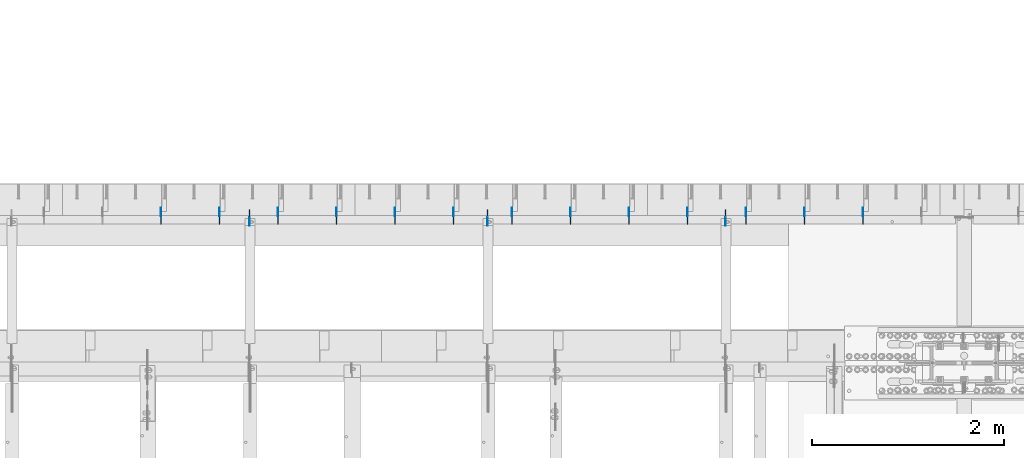
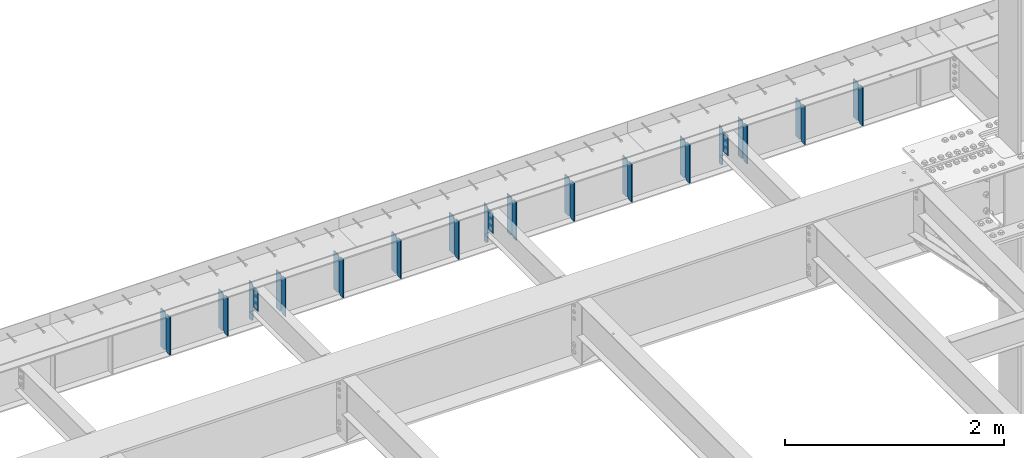
# One storey, part 1611 of 1763: 32 plates, 1 element without a shape of its own.
"""IFC2X3 building model written with IfcOpenShell, lengths in millimetres."""

from ifc_helpers import new_model, si_unit, frame, origin_with_axes, place, context, subcontext, project, spatial, faceted_brep, material, type_object, element, aggregate, save


model = new_model("IFC2X3")

# Units and contexts
model_context = context("Model", 3, precision=1e-05, world=origin_with_axes())
body_context = subcontext(model_context, "Body", "Model", "MODEL_VIEW")
ifc_project = project(units=[si_unit("LENGTHUNIT", "METRE", prefix="MILLI"), si_unit("AREAUNIT", "SQUARE_METRE"), si_unit("VOLUMEUNIT", "CUBIC_METRE"), si_unit("MASSUNIT", "GRAM", prefix="KILO"), si_unit("TIMEUNIT", "SECOND"), si_unit("PLANEANGLEUNIT", "RADIAN"), si_unit("SOLIDANGLEUNIT", "STERADIAN"), si_unit("THERMODYNAMICTEMPERATUREUNIT", "DEGREE_CELSIUS"), si_unit("LUMINOUSINTENSITYUNIT", "LUMEN")], contexts=[model_context])

# Site, building, storey
site_placement = place(None, origin_with_axes())
site = spatial("IfcSite", under=ifc_project, at=site_placement, CompositionType="ELEMENT")
building_placement = place(site_placement, origin_with_axes())
building = spatial("IfcBuilding", under=site, at=building_placement, Name="Undefined", CompositionType="ELEMENT")
storey_placement = place(building_placement, origin_with_axes())
storey = spatial("IfcBuildingStorey", under=building, at=storey_placement, Name="Undefined", CompositionType="ELEMENT", Elevation=0.0)

# Assembly, plates
assembly_placement = place(storey_placement, origin_with_axes())
assembly = element("IfcElementAssembly", 1, at=assembly_placement, inside=storey, Name="BEAM", AssemblyPlace="NOTDEFINED", PredefinedType="RIGID_FRAME")
ifc_material = material(Name="STEEL/A36")
plate_type_1 = type_object("IfcPlateType", PredefinedType="NOTDEFINED")
plate_1_placement = place(assembly_placement, frame((-73545.5341486984, 53568.6, 4752.975), z_axis=(0.0, 0.0, 1.0), x_axis=(0.0, 1.0, 0.0)))
plate_1 = element("IfcPlate", 2, at=plate_1_placement, type_object=plate_type_1, material=ifc_material, Name="PLATE", context=body_context, shape_type="Brep", body=[
    faceted_brep([(0.0, -4.76249999999982, 0.0), (0.0, -4.76249999999709, 428.625), (0.0, 4.76249999999709, 428.625), (0.0, 4.76249999999982, 0.0), (53.1812477111816, -4.76249999999709, 428.625), (53.1812477111816, 4.76249999999709, 428.625), (72.2312469482422, -4.76249999999709, 409.575000762939), (72.2312469482422, 4.76249999999709, 409.575000762939), (72.2312469482422, -4.76249999999709, 19.0499992370605), (72.2312469482422, 4.76249999999709, 19.0499992370605), (53.1812477111816, -4.76249999999709, 0.0), (53.1812477111816, 4.76249999999709, 0.0)], [[[0, 1, 2, 3]], [[1, 4, 5, 2]], [[4, 6, 7, 5]], [[6, 8, 9, 7]], [[8, 10, 11, 9]], [[10, 0, 3, 11]], [[5, 7, 9, 11, 3, 2]], [[10, 8, 6, 4, 1, 0]]]),
])
plate_2_placement = place(assembly_placement, frame((-74155.1341486984, 53568.6, 4752.975), z_axis=(0.0, 0.0, 1.0), x_axis=(0.0, 1.0, 0.0)))
plate_2 = element("IfcPlate", 3, at=plate_2_placement, type_object=plate_type_1, material=ifc_material, Name="PLATE", context=body_context, shape_type="Brep", body=[
    faceted_brep([(0.0, -4.76249999999982, 0.0), (0.0, -4.76249999999709, 428.625), (0.0, 4.76249999999709, 428.625), (0.0, 4.76249999999982, 0.0), (53.1812477111816, -4.76249999999709, 428.625), (53.1812477111816, 4.76249999999709, 428.625), (72.2312469482422, -4.76249999999709, 409.575000762939), (72.2312469482422, 4.76249999999709, 409.575000762939), (72.2312469482422, -4.76249999999709, 19.0499992370605), (72.2312469482422, 4.76249999999709, 19.0499992370605), (53.1812477111816, -4.76249999999709, 0.0), (53.1812477111816, 4.76249999999709, 0.0)], [[[0, 1, 2, 3]], [[1, 4, 5, 2]], [[4, 6, 7, 5]], [[6, 8, 9, 7]], [[8, 10, 11, 9]], [[10, 0, 3, 11]], [[5, 7, 9, 11, 3, 2]], [[10, 8, 6, 4, 1, 0]]]),
])
plate_3_placement = place(assembly_placement, frame((-74764.7341486983, 53568.6, 4752.975), z_axis=(0.0, 0.0, 1.0), x_axis=(0.0, 1.0, 0.0)))
plate_3 = element("IfcPlate", 4, at=plate_3_placement, type_object=plate_type_1, material=ifc_material, Name="PLATE", context=body_context, shape_type="Brep", body=[
    faceted_brep([(0.0, -4.76249999999982, 0.0), (0.0, -4.76249999999709, 428.625), (0.0, 4.76249999999709, 428.625), (0.0, 4.76249999999982, 0.0), (53.1812477111816, -4.76249999999709, 428.625), (53.1812477111816, 4.76249999999709, 428.625), (72.2312469482422, -4.76249999999709, 409.575000762939), (72.2312469482422, 4.76249999999709, 409.575000762939), (72.2312469482422, -4.76249999999709, 19.0499992370605), (72.2312469482422, 4.76249999999709, 19.0499992370605), (53.1812477111816, -4.76249999999709, 0.0), (53.1812477111816, 4.76249999999709, 0.0)], [[[0, 1, 2, 3]], [[1, 4, 5, 2]], [[4, 6, 7, 5]], [[6, 8, 9, 7]], [[8, 10, 11, 9]], [[10, 0, 3, 11]], [[5, 7, 9, 11, 3, 2]], [[10, 8, 6, 4, 1, 0]]]),
])
plate_4_placement = place(assembly_placement, frame((-75374.3341486984, 53568.6, 4752.975), z_axis=(0.0, 0.0, 1.0), x_axis=(0.0, 1.0, 0.0)))
plate_4 = element("IfcPlate", 5, at=plate_4_placement, type_object=plate_type_1, material=ifc_material, Name="PLATE", context=body_context, shape_type="Brep", body=[
    faceted_brep([(0.0, -4.76249999999982, 0.0), (0.0, -4.76249999999709, 428.625), (0.0, 4.76249999999709, 428.625), (0.0, 4.76249999999982, 0.0), (53.1812477111816, -4.76249999999709, 428.625), (53.1812477111816, 4.76249999999709, 428.625), (72.2312469482422, -4.76249999999709, 409.575000762939), (72.2312469482422, 4.76249999999709, 409.575000762939), (72.2312469482422, -4.76249999999709, 19.0499992370605), (72.2312469482422, 4.76249999999709, 19.0499992370605), (53.1812477111816, -4.76249999999709, 0.0), (53.1812477111816, 4.76249999999709, 0.0)], [[[0, 1, 2, 3]], [[1, 4, 5, 2]], [[4, 6, 7, 5]], [[6, 8, 9, 7]], [[8, 10, 11, 9]], [[10, 0, 3, 11]], [[5, 7, 9, 11, 3, 2]], [[10, 8, 6, 4, 1, 0]]]),
])
plate_5_placement = place(assembly_placement, frame((-75983.9341486984, 53568.6, 4752.975), z_axis=(0.0, 0.0, 1.0), x_axis=(0.0, 1.0, 0.0)))
plate_5 = element("IfcPlate", 6, at=plate_5_placement, type_object=plate_type_1, material=ifc_material, Name="PLATE", context=body_context, shape_type="Brep", body=[
    faceted_brep([(0.0, -4.76249999999982, 0.0), (0.0, -4.76249999999709, 428.625), (0.0, 4.76249999999709, 428.625), (0.0, 4.76249999999982, 0.0), (53.1812477111816, -4.76249999999709, 428.625), (53.1812477111816, 4.76249999999709, 428.625), (72.2312469482422, -4.76249999999709, 409.575000762939), (72.2312469482422, 4.76249999999709, 409.575000762939), (72.2312469482422, -4.76249999999709, 19.0499992370605), (72.2312469482422, 4.76249999999709, 19.0499992370605), (53.1812477111816, -4.76249999999709, 0.0), (53.1812477111816, 4.76249999999709, 0.0)], [[[0, 1, 2, 3]], [[1, 4, 5, 2]], [[4, 6, 7, 5]], [[6, 8, 9, 7]], [[8, 10, 11, 9]], [[10, 0, 3, 11]], [[5, 7, 9, 11, 3, 2]], [[10, 8, 6, 4, 1, 0]]]),
])
plate_6_placement = place(assembly_placement, frame((-76593.5341486984, 53568.6, 4752.975), z_axis=(0.0, 0.0, 1.0), x_axis=(0.0, 1.0, 0.0)))
plate_6 = element("IfcPlate", 7, at=plate_6_placement, type_object=plate_type_1, material=ifc_material, Name="PLATE", context=body_context, shape_type="Brep", body=[
    faceted_brep([(0.0, -4.76249999999982, 0.0), (0.0, -4.76249999999709, 428.625), (0.0, 4.76249999999709, 428.625), (0.0, 4.76249999999982, 0.0), (53.1812477111816, -4.76249999999709, 428.625), (53.1812477111816, 4.76249999999709, 428.625), (72.2312469482422, -4.76249999999709, 409.575000762939), (72.2312469482422, 4.76249999999709, 409.575000762939), (72.2312469482422, -4.76249999999709, 19.0499992370605), (72.2312469482422, 4.76249999999709, 19.0499992370605), (53.1812477111816, -4.76249999999709, 0.0), (53.1812477111816, 4.76249999999709, 0.0)], [[[0, 1, 2, 3]], [[1, 4, 5, 2]], [[4, 6, 7, 5]], [[6, 8, 9, 7]], [[8, 10, 11, 9]], [[10, 0, 3, 11]], [[5, 7, 9, 11, 3, 2]], [[10, 8, 6, 4, 1, 0]]]),
])
plate_7_placement = place(assembly_placement, frame((-77203.1341486984, 53568.6, 4752.975), z_axis=(0.0, 0.0, 1.0), x_axis=(0.0, 1.0, 0.0)))
plate_7 = element("IfcPlate", 8, at=plate_7_placement, type_object=plate_type_1, material=ifc_material, Name="PLATE", context=body_context, shape_type="Brep", body=[
    faceted_brep([(0.0, -4.76249999999982, 0.0), (0.0, -4.76249999999709, 428.625), (0.0, 4.76249999999709, 428.625), (0.0, 4.76249999999982, 0.0), (53.1812477111816, -4.76249999999709, 428.625), (53.1812477111816, 4.76249999999709, 428.625), (72.2312469482422, -4.76249999999709, 409.575000762939), (72.2312469482422, 4.76249999999709, 409.575000762939), (72.2312469482422, -4.76249999999709, 19.0499992370605), (72.2312469482422, 4.76249999999709, 19.0499992370605), (53.1812477111816, -4.76249999999709, 0.0), (53.1812477111816, 4.76249999999709, 0.0)], [[[0, 1, 2, 3]], [[1, 4, 5, 2]], [[4, 6, 7, 5]], [[6, 8, 9, 7]], [[8, 10, 11, 9]], [[10, 0, 3, 11]], [[5, 7, 9, 11, 3, 2]], [[10, 8, 6, 4, 1, 0]]]),
])
plate_8_placement = place(assembly_placement, frame((-77812.7341486983, 53568.6, 4752.975), z_axis=(0.0, 0.0, 1.0), x_axis=(0.0, 1.0, 0.0)))
plate_8 = element("IfcPlate", 9, at=plate_8_placement, type_object=plate_type_1, material=ifc_material, Name="PLATE", context=body_context, shape_type="Brep", body=[
    faceted_brep([(0.0, -4.76249999999982, 0.0), (0.0, -4.76249999999709, 428.625), (0.0, 4.76249999999709, 428.625), (0.0, 4.76249999999982, 0.0), (53.1812477111816, -4.76249999999709, 428.625), (53.1812477111816, 4.76249999999709, 428.625), (72.2312469482422, -4.76249999999709, 409.575000762939), (72.2312469482422, 4.76249999999709, 409.575000762939), (72.2312469482422, -4.76249999999709, 19.0499992370605), (72.2312469482422, 4.76249999999709, 19.0499992370605), (53.1812477111816, -4.76249999999709, 0.0), (53.1812477111816, 4.76249999999709, 0.0)], [[[0, 1, 2, 3]], [[1, 4, 5, 2]], [[4, 6, 7, 5]], [[6, 8, 9, 7]], [[8, 10, 11, 9]], [[10, 0, 3, 11]], [[5, 7, 9, 11, 3, 2]], [[10, 8, 6, 4, 1, 0]]]),
])
plate_9_placement = place(assembly_placement, frame((-78422.3341486984, 53568.6, 4752.975), z_axis=(0.0, 0.0, 1.0), x_axis=(0.0, 1.0, 0.0)))
plate_9 = element("IfcPlate", 10, at=plate_9_placement, type_object=plate_type_1, material=ifc_material, Name="PLATE", context=body_context, shape_type="Brep", body=[
    faceted_brep([(0.0, -4.76249999999982, 0.0), (0.0, -4.76249999999709, 428.625), (0.0, 4.76249999999709, 428.625), (0.0, 4.76249999999982, 0.0), (53.1812477111816, -4.76249999999709, 428.625), (53.1812477111816, 4.76249999999709, 428.625), (72.2312469482422, -4.76249999999709, 409.575000762939), (72.2312469482422, 4.76249999999709, 409.575000762939), (72.2312469482422, -4.76249999999709, 19.0499992370605), (72.2312469482422, 4.76249999999709, 19.0499992370605), (53.1812477111816, -4.76249999999709, 0.0), (53.1812477111816, 4.76249999999709, 0.0)], [[[0, 1, 2, 3]], [[1, 4, 5, 2]], [[4, 6, 7, 5]], [[6, 8, 9, 7]], [[8, 10, 11, 9]], [[10, 0, 3, 11]], [[5, 7, 9, 11, 3, 2]], [[10, 8, 6, 4, 1, 0]]]),
])
plate_10_placement = place(assembly_placement, frame((-79031.9341486984, 53568.6, 4752.975), z_axis=(0.0, 0.0, 1.0), x_axis=(0.0, 1.0, 0.0)))
plate_10 = element("IfcPlate", 11, at=plate_10_placement, type_object=plate_type_1, material=ifc_material, Name="PLATE", context=body_context, shape_type="Brep", body=[
    faceted_brep([(0.0, -4.76249999999982, 0.0), (0.0, -4.76249999999709, 428.625), (0.0, 4.76249999999709, 428.625), (0.0, 4.76249999999982, 0.0), (53.1812477111816, -4.76249999999709, 428.625), (53.1812477111816, 4.76249999999709, 428.625), (72.2312469482422, -4.76249999999709, 409.575000762939), (72.2312469482422, 4.76249999999709, 409.575000762939), (72.2312469482422, -4.76249999999709, 19.0499992370605), (72.2312469482422, 4.76249999999709, 19.0499992370605), (53.1812477111816, -4.76249999999709, 0.0), (53.1812477111816, 4.76249999999709, 0.0)], [[[0, 1, 2, 3]], [[1, 4, 5, 2]], [[4, 6, 7, 5]], [[6, 8, 9, 7]], [[8, 10, 11, 9]], [[10, 0, 3, 11]], [[5, 7, 9, 11, 3, 2]], [[10, 8, 6, 4, 1, 0]]]),
])
plate_11_placement = place(assembly_placement, frame((-79641.5341486984, 53568.6, 4752.975), z_axis=(0.0, 0.0, 1.0), x_axis=(0.0, 1.0, 0.0)))
plate_11 = element("IfcPlate", 12, at=plate_11_placement, type_object=plate_type_1, material=ifc_material, Name="PLATE", context=body_context, shape_type="Brep", body=[
    faceted_brep([(0.0, -4.76249999999982, 0.0), (0.0, -4.76249999999709, 428.625), (0.0, 4.76249999999709, 428.625), (0.0, 4.76249999999982, 0.0), (53.1812477111816, -4.76249999999709, 428.625), (53.1812477111816, 4.76249999999709, 428.625), (72.2312469482422, -4.76249999999709, 409.575000762939), (72.2312469482422, 4.76249999999709, 409.575000762939), (72.2312469482422, -4.76249999999709, 19.0499992370605), (72.2312469482422, 4.76249999999709, 19.0499992370605), (53.1812477111816, -4.76249999999709, 0.0), (53.1812477111816, 4.76249999999709, 0.0)], [[[0, 1, 2, 3]], [[1, 4, 5, 2]], [[4, 6, 7, 5]], [[6, 8, 9, 7]], [[8, 10, 11, 9]], [[10, 0, 3, 11]], [[5, 7, 9, 11, 3, 2]], [[10, 8, 6, 4, 1, 0]]]),
])
plate_12_placement = place(assembly_placement, frame((-80251.1341486984, 53568.6, 4752.975), z_axis=(0.0, 0.0, 1.0), x_axis=(0.0, 1.0, 0.0)))
plate_12 = element("IfcPlate", 13, at=plate_12_placement, type_object=plate_type_1, material=ifc_material, Name="PLATE", context=body_context, shape_type="Brep", body=[
    faceted_brep([(0.0, -4.76249999999982, 0.0), (0.0, -4.76249999999709, 428.625), (0.0, 4.76249999999709, 428.625), (0.0, 4.76249999999982, 0.0), (53.1812477111816, -4.76249999999709, 428.625), (53.1812477111816, 4.76249999999709, 428.625), (72.2312469482422, -4.76249999999709, 409.575000762939), (72.2312469482422, 4.76249999999709, 409.575000762939), (72.2312469482422, -4.76249999999709, 19.0499992370605), (72.2312469482422, 4.76249999999709, 19.0499992370605), (53.1812477111816, -4.76249999999709, 0.0), (53.1812477111816, 4.76249999999709, 0.0)], [[[0, 1, 2, 3]], [[1, 4, 5, 2]], [[4, 6, 7, 5]], [[6, 8, 9, 7]], [[8, 10, 11, 9]], [[10, 0, 3, 11]], [[5, 7, 9, 11, 3, 2]], [[10, 8, 6, 4, 1, 0]]]),
])
plate_13_placement = place(assembly_placement, frame((-80860.7341486983, 53568.6, 4752.975), z_axis=(0.0, 0.0, 1.0), x_axis=(0.0, 1.0, 0.0)))
plate_13 = element("IfcPlate", 14, at=plate_13_placement, type_object=plate_type_1, material=ifc_material, Name="PLATE", context=body_context, shape_type="Brep", body=[
    faceted_brep([(0.0, -4.76249999999982, 0.0), (0.0, -4.76249999999709, 428.625), (0.0, 4.76249999999709, 428.625), (0.0, 4.76249999999982, 0.0), (53.1812477111816, -4.76249999999709, 428.625), (53.1812477111816, 4.76249999999709, 428.625), (72.2312469482422, -4.76249999999709, 409.575000762939), (72.2312469482422, 4.76249999999709, 409.575000762939), (72.2312469482422, -4.76249999999709, 19.0499992370605), (72.2312469482422, 4.76249999999709, 19.0499992370605), (53.1812477111816, -4.76249999999709, 0.0), (53.1812477111816, 4.76249999999709, 0.0)], [[[0, 1, 2, 3]], [[1, 4, 5, 2]], [[4, 6, 7, 5]], [[6, 8, 9, 7]], [[8, 10, 11, 9]], [[10, 0, 3, 11]], [[5, 7, 9, 11, 3, 2]], [[10, 8, 6, 4, 1, 0]]]),
])
plate_type_2 = type_object("IfcPlateType", PredefinedType="NOTDEFINED")
plate_14_placement = place(assembly_placement, frame((-73545.5341486984, 53648.76875, 4752.975), z_axis=(0.0, 0.0, 1.0), x_axis=(0.0, 1.0, 0.0)))
plate_14 = element("IfcPlate", 15, at=plate_14_placement, type_object=plate_type_2, material=ifc_material, Name="PLATE", context=body_context, shape_type="Brep", body=[
    faceted_brep([(6.96272763889283e-08, -4.76249999999709, 19.0499992370605), (0.0, -4.76249999999709, 409.575000762939), (0.0, 4.76249999999709, 409.575000762939), (6.96454662829638e-08, 4.76249999999709, 19.0499992370605), (19.0499992370605, -4.76249999999709, 428.625), (19.0499992370605, 4.76249999999709, 428.625), (89.6937484741211, -4.76249999999709, 428.625), (89.6937484741211, 4.76249999999709, 428.625), (89.6937484741211, -4.76249999999709, 0.0), (89.6937484741211, 4.76249999999709, 0.0), (19.0499992370533, -4.76249999996799, -2.09183781407773e-11), (19.0499992370678, 4.76250000003347, -2.09183781407773e-11)], [[[0, 1, 2, 3]], [[1, 4, 5, 2]], [[4, 6, 7, 5]], [[6, 8, 9, 7]], [[8, 10, 11, 9]], [[10, 0, 3, 11]], [[5, 7, 9, 11, 3, 2]], [[10, 8, 6, 4, 1, 0]]]),
])
plate_15_placement = place(assembly_placement, frame((-74155.1341486984, 53648.76875, 4752.975), z_axis=(0.0, 0.0, 1.0), x_axis=(0.0, 1.0, 0.0)))
plate_15 = element("IfcPlate", 16, at=plate_15_placement, type_object=plate_type_2, material=ifc_material, Name="PLATE", context=body_context, shape_type="Brep", body=[
    faceted_brep([(6.96272763889283e-08, -4.76249999999709, 19.0499992370605), (0.0, -4.76249999999709, 409.575000762939), (0.0, 4.76249999999709, 409.575000762939), (6.96454662829638e-08, 4.76249999999709, 19.0499992370605), (19.0499992370605, -4.76249999999709, 428.625), (19.0499992370605, 4.76249999999709, 428.625), (89.6937484741211, -4.76249999999709, 428.625), (89.6937484741211, 4.76249999999709, 428.625), (89.6937484741211, -4.76249999999709, 0.0), (89.6937484741211, 4.76249999999709, 0.0), (19.0499992370533, -4.76249999996799, -2.09183781407773e-11), (19.0499992370678, 4.76250000003347, -2.09183781407773e-11)], [[[0, 1, 2, 3]], [[1, 4, 5, 2]], [[4, 6, 7, 5]], [[6, 8, 9, 7]], [[8, 10, 11, 9]], [[10, 0, 3, 11]], [[5, 7, 9, 11, 3, 2]], [[10, 8, 6, 4, 1, 0]]]),
])
plate_16_placement = place(assembly_placement, frame((-74764.7341486983, 53648.76875, 4752.975), z_axis=(0.0, 0.0, 1.0), x_axis=(0.0, 1.0, 0.0)))
plate_16 = element("IfcPlate", 17, at=plate_16_placement, type_object=plate_type_2, material=ifc_material, Name="PLATE", context=body_context, shape_type="Brep", body=[
    faceted_brep([(6.96272763889283e-08, -4.76249999999709, 19.0499992370605), (0.0, -4.76249999999709, 409.575000762939), (0.0, 4.76249999999709, 409.575000762939), (6.96454662829638e-08, 4.76249999999709, 19.0499992370605), (19.0499992370605, -4.76249999999709, 428.625), (19.0499992370605, 4.76249999999709, 428.625), (89.6937484741211, -4.76249999999709, 428.625), (89.6937484741211, 4.76249999999709, 428.625), (89.6937484741211, -4.76249999999709, 0.0), (89.6937484741211, 4.76249999999709, 0.0), (19.0499992370533, -4.76249999996799, -2.09183781407773e-11), (19.0499992370678, 4.76250000003347, -2.09183781407773e-11)], [[[0, 1, 2, 3]], [[1, 4, 5, 2]], [[4, 6, 7, 5]], [[6, 8, 9, 7]], [[8, 10, 11, 9]], [[10, 0, 3, 11]], [[5, 7, 9, 11, 3, 2]], [[10, 8, 6, 4, 1, 0]]]),
])
plate_17_placement = place(assembly_placement, frame((-75374.3341486984, 53648.76875, 4752.975), z_axis=(0.0, 0.0, 1.0), x_axis=(0.0, 1.0, 0.0)))
plate_17 = element("IfcPlate", 18, at=plate_17_placement, type_object=plate_type_2, material=ifc_material, Name="PLATE", context=body_context, shape_type="Brep", body=[
    faceted_brep([(6.96272763889283e-08, -4.76249999999709, 19.0499992370605), (0.0, -4.76249999999709, 409.575000762939), (0.0, 4.76249999999709, 409.575000762939), (6.96454662829638e-08, 4.76249999999709, 19.0499992370605), (19.0499992370605, -4.76249999999709, 428.625), (19.0499992370605, 4.76249999999709, 428.625), (89.6937484741211, -4.76249999999709, 428.625), (89.6937484741211, 4.76249999999709, 428.625), (89.6937484741211, -4.76249999999709, 0.0), (89.6937484741211, 4.76249999999709, 0.0), (19.0499992370533, -4.76249999996799, -2.09183781407773e-11), (19.0499992370678, 4.76250000003347, -2.09183781407773e-11)], [[[0, 1, 2, 3]], [[1, 4, 5, 2]], [[4, 6, 7, 5]], [[6, 8, 9, 7]], [[8, 10, 11, 9]], [[10, 0, 3, 11]], [[5, 7, 9, 11, 3, 2]], [[10, 8, 6, 4, 1, 0]]]),
])
plate_18_placement = place(assembly_placement, frame((-75983.9341486984, 53648.76875, 4752.975), z_axis=(0.0, 0.0, 1.0), x_axis=(0.0, 1.0, 0.0)))
plate_18 = element("IfcPlate", 19, at=plate_18_placement, type_object=plate_type_2, material=ifc_material, Name="PLATE", context=body_context, shape_type="Brep", body=[
    faceted_brep([(6.96272763889283e-08, -4.76249999999709, 19.0499992370605), (0.0, -4.76249999999709, 409.575000762939), (0.0, 4.76249999999709, 409.575000762939), (6.96454662829638e-08, 4.76249999999709, 19.0499992370605), (19.0499992370605, -4.76249999999709, 428.625), (19.0499992370605, 4.76249999999709, 428.625), (89.6937484741211, -4.76249999999709, 428.625), (89.6937484741211, 4.76249999999709, 428.625), (89.6937484741211, -4.76249999999709, 0.0), (89.6937484741211, 4.76249999999709, 0.0), (19.0499992370533, -4.76249999996799, -2.09183781407773e-11), (19.0499992370678, 4.76250000003347, -2.09183781407773e-11)], [[[0, 1, 2, 3]], [[1, 4, 5, 2]], [[4, 6, 7, 5]], [[6, 8, 9, 7]], [[8, 10, 11, 9]], [[10, 0, 3, 11]], [[5, 7, 9, 11, 3, 2]], [[10, 8, 6, 4, 1, 0]]]),
])
plate_19_placement = place(assembly_placement, frame((-76593.5341486984, 53648.76875, 4752.975), z_axis=(0.0, 0.0, 1.0), x_axis=(0.0, 1.0, 0.0)))
plate_19 = element("IfcPlate", 20, at=plate_19_placement, type_object=plate_type_2, material=ifc_material, Name="PLATE", context=body_context, shape_type="Brep", body=[
    faceted_brep([(6.96272763889283e-08, -4.76249999999709, 19.0499992370605), (0.0, -4.76249999999709, 409.575000762939), (0.0, 4.76249999999709, 409.575000762939), (6.96454662829638e-08, 4.76249999999709, 19.0499992370605), (19.0499992370605, -4.76249999999709, 428.625), (19.0499992370605, 4.76249999999709, 428.625), (89.6937484741211, -4.76249999999709, 428.625), (89.6937484741211, 4.76249999999709, 428.625), (89.6937484741211, -4.76249999999709, 0.0), (89.6937484741211, 4.76249999999709, 0.0), (19.0499992370533, -4.76249999996799, -2.09183781407773e-11), (19.0499992370678, 4.76250000003347, -2.09183781407773e-11)], [[[0, 1, 2, 3]], [[1, 4, 5, 2]], [[4, 6, 7, 5]], [[6, 8, 9, 7]], [[8, 10, 11, 9]], [[10, 0, 3, 11]], [[5, 7, 9, 11, 3, 2]], [[10, 8, 6, 4, 1, 0]]]),
])
plate_20_placement = place(assembly_placement, frame((-77203.1341486984, 53648.76875, 4752.975), z_axis=(0.0, 0.0, 1.0), x_axis=(0.0, 1.0, 0.0)))
plate_20 = element("IfcPlate", 21, at=plate_20_placement, type_object=plate_type_2, material=ifc_material, Name="PLATE", context=body_context, shape_type="Brep", body=[
    faceted_brep([(6.96272763889283e-08, -4.76249999999709, 19.0499992370605), (0.0, -4.76249999999709, 409.575000762939), (0.0, 4.76249999999709, 409.575000762939), (6.96454662829638e-08, 4.76249999999709, 19.0499992370605), (19.0499992370605, -4.76249999999709, 428.625), (19.0499992370605, 4.76249999999709, 428.625), (89.6937484741211, -4.76249999999709, 428.625), (89.6937484741211, 4.76249999999709, 428.625), (89.6937484741211, -4.76249999999709, 0.0), (89.6937484741211, 4.76249999999709, 0.0), (19.0499992370533, -4.76249999996799, -2.09183781407773e-11), (19.0499992370678, 4.76250000003347, -2.09183781407773e-11)], [[[0, 1, 2, 3]], [[1, 4, 5, 2]], [[4, 6, 7, 5]], [[6, 8, 9, 7]], [[8, 10, 11, 9]], [[10, 0, 3, 11]], [[5, 7, 9, 11, 3, 2]], [[10, 8, 6, 4, 1, 0]]]),
])
plate_21_placement = place(assembly_placement, frame((-77812.7341486983, 53648.76875, 4752.975), z_axis=(0.0, 0.0, 1.0), x_axis=(0.0, 1.0, 0.0)))
plate_21 = element("IfcPlate", 22, at=plate_21_placement, type_object=plate_type_2, material=ifc_material, Name="PLATE", context=body_context, shape_type="Brep", body=[
    faceted_brep([(6.96272763889283e-08, -4.76249999999709, 19.0499992370605), (0.0, -4.76249999999709, 409.575000762939), (0.0, 4.76249999999709, 409.575000762939), (6.96454662829638e-08, 4.76249999999709, 19.0499992370605), (19.0499992370605, -4.76249999999709, 428.625), (19.0499992370605, 4.76249999999709, 428.625), (89.6937484741211, -4.76249999999709, 428.625), (89.6937484741211, 4.76249999999709, 428.625), (89.6937484741211, -4.76249999999709, 0.0), (89.6937484741211, 4.76249999999709, 0.0), (19.0499992370533, -4.76249999996799, -2.09183781407773e-11), (19.0499992370678, 4.76250000003347, -2.09183781407773e-11)], [[[0, 1, 2, 3]], [[1, 4, 5, 2]], [[4, 6, 7, 5]], [[6, 8, 9, 7]], [[8, 10, 11, 9]], [[10, 0, 3, 11]], [[5, 7, 9, 11, 3, 2]], [[10, 8, 6, 4, 1, 0]]]),
])
plate_22_placement = place(assembly_placement, frame((-78422.3341486984, 53648.76875, 4752.975), z_axis=(0.0, 0.0, 1.0), x_axis=(0.0, 1.0, 0.0)))
plate_22 = element("IfcPlate", 23, at=plate_22_placement, type_object=plate_type_2, material=ifc_material, Name="PLATE", context=body_context, shape_type="Brep", body=[
    faceted_brep([(6.96272763889283e-08, -4.76249999999709, 19.0499992370605), (0.0, -4.76249999999709, 409.575000762939), (0.0, 4.76249999999709, 409.575000762939), (6.96454662829638e-08, 4.76249999999709, 19.0499992370605), (19.0499992370605, -4.76249999999709, 428.625), (19.0499992370605, 4.76249999999709, 428.625), (89.6937484741211, -4.76249999999709, 428.625), (89.6937484741211, 4.76249999999709, 428.625), (89.6937484741211, -4.76249999999709, 0.0), (89.6937484741211, 4.76249999999709, 0.0), (19.0499992370533, -4.76249999996799, -2.09183781407773e-11), (19.0499992370678, 4.76250000003347, -2.09183781407773e-11)], [[[0, 1, 2, 3]], [[1, 4, 5, 2]], [[4, 6, 7, 5]], [[6, 8, 9, 7]], [[8, 10, 11, 9]], [[10, 0, 3, 11]], [[5, 7, 9, 11, 3, 2]], [[10, 8, 6, 4, 1, 0]]]),
])
plate_23_placement = place(assembly_placement, frame((-79031.9341486984, 53648.76875, 4752.975), z_axis=(0.0, 0.0, 1.0), x_axis=(0.0, 1.0, 0.0)))
plate_23 = element("IfcPlate", 24, at=plate_23_placement, type_object=plate_type_2, material=ifc_material, Name="PLATE", context=body_context, shape_type="Brep", body=[
    faceted_brep([(6.96272763889283e-08, -4.76249999999709, 19.0499992370605), (0.0, -4.76249999999709, 409.575000762939), (0.0, 4.76249999999709, 409.575000762939), (6.96454662829638e-08, 4.76249999999709, 19.0499992370605), (19.0499992370605, -4.76249999999709, 428.625), (19.0499992370605, 4.76249999999709, 428.625), (89.6937484741211, -4.76249999999709, 428.625), (89.6937484741211, 4.76249999999709, 428.625), (89.6937484741211, -4.76249999999709, 0.0), (89.6937484741211, 4.76249999999709, 0.0), (19.0499992370533, -4.76249999996799, -2.09183781407773e-11), (19.0499992370678, 4.76250000003347, -2.09183781407773e-11)], [[[0, 1, 2, 3]], [[1, 4, 5, 2]], [[4, 6, 7, 5]], [[6, 8, 9, 7]], [[8, 10, 11, 9]], [[10, 0, 3, 11]], [[5, 7, 9, 11, 3, 2]], [[10, 8, 6, 4, 1, 0]]]),
])
plate_24_placement = place(assembly_placement, frame((-79641.5341486984, 53648.76875, 4752.975), z_axis=(0.0, 0.0, 1.0), x_axis=(0.0, 1.0, 0.0)))
plate_24 = element("IfcPlate", 25, at=plate_24_placement, type_object=plate_type_2, material=ifc_material, Name="PLATE", context=body_context, shape_type="Brep", body=[
    faceted_brep([(6.96272763889283e-08, -4.76249999999709, 19.0499992370605), (0.0, -4.76249999999709, 409.575000762939), (0.0, 4.76249999999709, 409.575000762939), (6.96454662829638e-08, 4.76249999999709, 19.0499992370605), (19.0499992370605, -4.76249999999709, 428.625), (19.0499992370605, 4.76249999999709, 428.625), (89.6937484741211, -4.76249999999709, 428.625), (89.6937484741211, 4.76249999999709, 428.625), (89.6937484741211, -4.76249999999709, 0.0), (89.6937484741211, 4.76249999999709, 0.0), (19.0499992370533, -4.76249999996799, -2.09183781407773e-11), (19.0499992370678, 4.76250000003347, -2.09183781407773e-11)], [[[0, 1, 2, 3]], [[1, 4, 5, 2]], [[4, 6, 7, 5]], [[6, 8, 9, 7]], [[8, 10, 11, 9]], [[10, 0, 3, 11]], [[5, 7, 9, 11, 3, 2]], [[10, 8, 6, 4, 1, 0]]]),
])
plate_25_placement = place(assembly_placement, frame((-80251.1341486984, 53648.76875, 4752.975), z_axis=(0.0, 0.0, 1.0), x_axis=(0.0, 1.0, 0.0)))
plate_25 = element("IfcPlate", 26, at=plate_25_placement, type_object=plate_type_2, material=ifc_material, Name="PLATE", context=body_context, shape_type="Brep", body=[
    faceted_brep([(6.96272763889283e-08, -4.76249999999709, 19.0499992370605), (0.0, -4.76249999999709, 409.575000762939), (0.0, 4.76249999999709, 409.575000762939), (6.96454662829638e-08, 4.76249999999709, 19.0499992370605), (19.0499992370605, -4.76249999999709, 428.625), (19.0499992370605, 4.76249999999709, 428.625), (89.6937484741211, -4.76249999999709, 428.625), (89.6937484741211, 4.76249999999709, 428.625), (89.6937484741211, -4.76249999999709, 0.0), (89.6937484741211, 4.76249999999709, 0.0), (19.0499992370533, -4.76249999996799, -2.09183781407773e-11), (19.0499992370678, 4.76250000003347, -2.09183781407773e-11)], [[[0, 1, 2, 3]], [[1, 4, 5, 2]], [[4, 6, 7, 5]], [[6, 8, 9, 7]], [[8, 10, 11, 9]], [[10, 0, 3, 11]], [[5, 7, 9, 11, 3, 2]], [[10, 8, 6, 4, 1, 0]]]),
])
plate_26_placement = place(assembly_placement, frame((-80860.7341486983, 53648.76875, 4752.975), z_axis=(0.0, 0.0, 1.0), x_axis=(0.0, 1.0, 0.0)))
plate_26 = element("IfcPlate", 27, at=plate_26_placement, type_object=plate_type_2, material=ifc_material, Name="PLATE", context=body_context, shape_type="Brep", body=[
    faceted_brep([(6.96272763889283e-08, -4.76249999999709, 19.0499992370605), (0.0, -4.76249999999709, 409.575000762939), (0.0, 4.76249999999709, 409.575000762939), (6.96454662829638e-08, 4.76249999999709, 19.0499992370605), (19.0499992370605, -4.76249999999709, 428.625), (19.0499992370605, 4.76249999999709, 428.625), (89.6937484741211, -4.76249999999709, 428.625), (89.6937484741211, 4.76249999999709, 428.625), (89.6937484741211, -4.76249999999709, 0.0), (89.6937484741211, 4.76249999999709, 0.0), (19.0499992370533, -4.76249999996799, -2.09183781407773e-11), (19.0499992370678, 4.76250000003347, -2.09183781407773e-11)], [[[0, 1, 2, 3]], [[1, 4, 5, 2]], [[4, 6, 7, 5]], [[6, 8, 9, 7]], [[8, 10, 11, 9]], [[10, 0, 3, 11]], [[5, 7, 9, 11, 3, 2]], [[10, 8, 6, 4, 1, 0]]]),
])
plate_type_3 = type_object("IfcPlateType", PredefinedType="NOTDEFINED")
plate_27_placement = place(assembly_placement, frame((-74978.1206070317, 53640.83125, 5156.2), z_axis=(0.0, -1.0, 0.0), x_axis=(0.0, 0.0, -1.0)))
plate_27 = element("IfcPlate", 28, at=plate_27_placement, type_object=plate_type_3, material=ifc_material, Name="PLATE", context=body_context, shape_type="Brep", body=[
    faceted_brep([(1.81898940354586e-12, -3.17500000000291, 0.0), (0.0, -3.17499999999927, 88.9000015258789), (0.0, 3.17499999999927, 88.9000015258789), (-1.81898940354586e-12, 3.17499999997381, 0.0), (228.600006103516, -3.17499999999927, 88.9000015258789), (228.600006103516, 3.17499999999927, 88.9000015258789), (228.600006103516, -3.17500000001019, -7.27595761418343e-12), (228.600006103516, 3.17499999999563, -7.27595761418343e-12)], [[[0, 1, 2, 3]], [[1, 4, 5, 2]], [[4, 6, 7, 5]], [[6, 0, 3, 7]], [[5, 7, 3, 2]], [[6, 4, 1, 0]]]),
])
plate_28_placement = place(assembly_placement, frame((-77458.9862320317, 53640.83125, 5156.2), z_axis=(0.0, -1.0, 0.0), x_axis=(0.0, 0.0, -1.0)))
plate_28 = element("IfcPlate", 29, at=plate_28_placement, type_object=plate_type_3, material=ifc_material, Name="PLATE", context=body_context, shape_type="Brep", body=[
    faceted_brep([(1.81898940354586e-12, -3.17500000000291, 0.0), (0.0, -3.17499999999927, 88.9000015258789), (0.0, 3.17499999999927, 88.9000015258789), (-1.81898940354586e-12, 3.17499999997381, 0.0), (228.600006103516, -3.17499999999927, 88.9000015258789), (228.600006103516, 3.17499999999927, 88.9000015258789), (228.600006103516, -3.17500000001019, -7.27595761418343e-12), (228.600006103516, 3.17499999999563, -7.27595761418343e-12)], [[[0, 1, 2, 3]], [[1, 4, 5, 2]], [[4, 6, 7, 5]], [[6, 0, 3, 7]], [[5, 7, 3, 2]], [[6, 4, 1, 0]]]),
])
plate_29_placement = place(assembly_placement, frame((-79939.5872736983, 53640.83125, 5156.2), z_axis=(0.0, -1.0, 0.0), x_axis=(0.0, 0.0, -1.0)))
plate_29 = element("IfcPlate", 30, at=plate_29_placement, type_object=plate_type_3, material=ifc_material, Name="PLATE", context=body_context, shape_type="Brep", body=[
    faceted_brep([(1.81898940354586e-12, -3.17500000000291, 0.0), (0.0, -3.17499999999927, 88.9000015258789), (0.0, 3.17499999999927, 88.9000015258789), (-1.81898940354586e-12, 3.17499999997381, 0.0), (228.600006103516, -3.17499999999927, 88.9000015258789), (228.600006103516, 3.17499999999927, 88.9000015258789), (228.600006103516, -3.17500000001019, -7.27595761418343e-12), (228.600006103516, 3.17499999999563, -7.27595761418343e-12)], [[[0, 1, 2, 3]], [[1, 4, 5, 2]], [[4, 6, 7, 5]], [[6, 0, 3, 7]], [[5, 7, 3, 2]], [[6, 4, 1, 0]]]),
])
plate_type_4 = type_object("IfcPlateType", PredefinedType="NOTDEFINED")
plate_30_placement = place(assembly_placement, frame((-74978.1206070794, 53648.76875, 4754.5625), z_axis=(0.0, 0.0, 1.0), x_axis=(0.0, 1.0, 0.0)))
plate_30 = element("IfcPlate", 31, at=plate_30_placement, type_object=plate_type_4, material=ifc_material, Name="PLATE", context=body_context, shape_type="Brep", body=[
    faceted_brep([(0.0, -3.17499999987194, 25.4000000001051), (0.0, -3.17500000000291, 400.050012588501), (0.0, 3.17500000000291, 400.050012588501), (0.0, 3.17500000014843, 25.4000000001197), (25.3999996185303, -3.17500000000291, 425.450012207031), (25.3999996185303, 3.17500000000291, 425.450012207031), (69.8499984741211, -3.17500000000291, 425.450012207031), (69.8499984741211, 3.17500000000291, 425.450012207031), (69.8499984741211, -3.17500000000291, 0.0), (69.8499984741211, 3.17500000000291, 0.0), (25.3999996184939, -3.17499999996653, 1.2732925824821e-11), (25.3999996185303, 3.17499995230901, 0.0)], [[[0, 1, 2, 3]], [[1, 4, 5, 2]], [[4, 6, 7, 5]], [[6, 8, 9, 7]], [[8, 10, 11, 9]], [[10, 0, 3, 11]], [[5, 7, 9, 11, 3, 2]], [[10, 8, 6, 4, 1, 0]]]),
])
plate_31_placement = place(assembly_placement, frame((-77458.9862320794, 53648.76875, 4754.5625), z_axis=(0.0, 0.0, 1.0), x_axis=(0.0, 1.0, 0.0)))
plate_31 = element("IfcPlate", 32, at=plate_31_placement, type_object=plate_type_4, material=ifc_material, Name="PLATE", context=body_context, shape_type="Brep", body=[
    faceted_brep([(0.0, -3.17499999987194, 25.4000000001051), (0.0, -3.17500000000291, 400.050012588501), (0.0, 3.17500000000291, 400.050012588501), (0.0, 3.17500000014843, 25.4000000001197), (25.3999996185303, -3.17500000000291, 425.450012207031), (25.3999996185303, 3.17500000000291, 425.450012207031), (69.8499984741211, -3.17500000000291, 425.450012207031), (69.8499984741211, 3.17500000000291, 425.450012207031), (69.8499984741211, -3.17500000000291, 0.0), (69.8499984741211, 3.17500000000291, 0.0), (25.3999996184939, -3.17499999996653, 1.2732925824821e-11), (25.3999996185303, 3.17499995230901, 0.0)], [[[0, 1, 2, 3]], [[1, 4, 5, 2]], [[4, 6, 7, 5]], [[6, 8, 9, 7]], [[8, 10, 11, 9]], [[10, 0, 3, 11]], [[5, 7, 9, 11, 3, 2]], [[10, 8, 6, 4, 1, 0]]]),
])
plate_32_placement = place(assembly_placement, frame((-79939.587273746, 53648.76875, 4754.5625), z_axis=(0.0, 0.0, 1.0), x_axis=(0.0, 1.0, 0.0)))
plate_32 = element("IfcPlate", 33, at=plate_32_placement, type_object=plate_type_4, material=ifc_material, Name="PLATE", context=body_context, shape_type="Brep", body=[
    faceted_brep([(0.0, -3.17499999987194, 25.4000000001051), (0.0, -3.17500000000291, 400.050012588501), (0.0, 3.17500000000291, 400.050012588501), (0.0, 3.17500000014843, 25.4000000001197), (25.3999996185303, -3.17500000000291, 425.450012207031), (25.3999996185303, 3.17500000000291, 425.450012207031), (69.8499984741211, -3.17500000000291, 425.450012207031), (69.8499984741211, 3.17500000000291, 425.450012207031), (69.8499984741211, -3.17500000000291, 0.0), (69.8499984741211, 3.17500000000291, 0.0), (25.3999996184939, -3.17499999996653, 1.2732925824821e-11), (25.3999996185303, 3.17499995230901, 0.0)], [[[0, 1, 2, 3]], [[1, 4, 5, 2]], [[4, 6, 7, 5]], [[6, 8, 9, 7]], [[8, 10, 11, 9]], [[10, 0, 3, 11]], [[5, 7, 9, 11, 3, 2]], [[10, 8, 6, 4, 1, 0]]]),
])
aggregate(assembly, [plate_1, plate_14, plate_2, plate_15, plate_3, plate_16, plate_4, plate_17, plate_5, plate_18, plate_6, plate_19, plate_7, plate_20, plate_8, plate_21, plate_9, plate_22, plate_10, plate_23, plate_11, plate_24, plate_12, plate_25, plate_13, plate_26, plate_30, plate_27, plate_31, plate_28, plate_32, plate_29])

save(model, "model.ifc")
